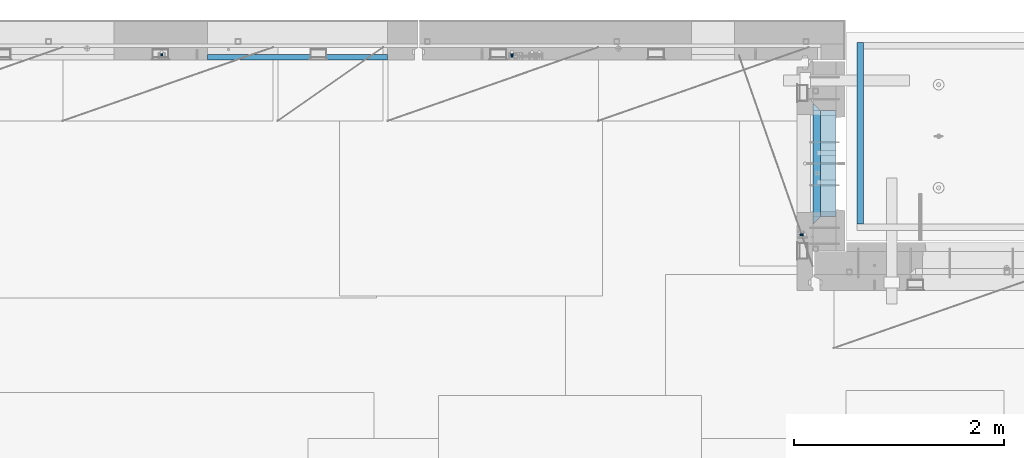
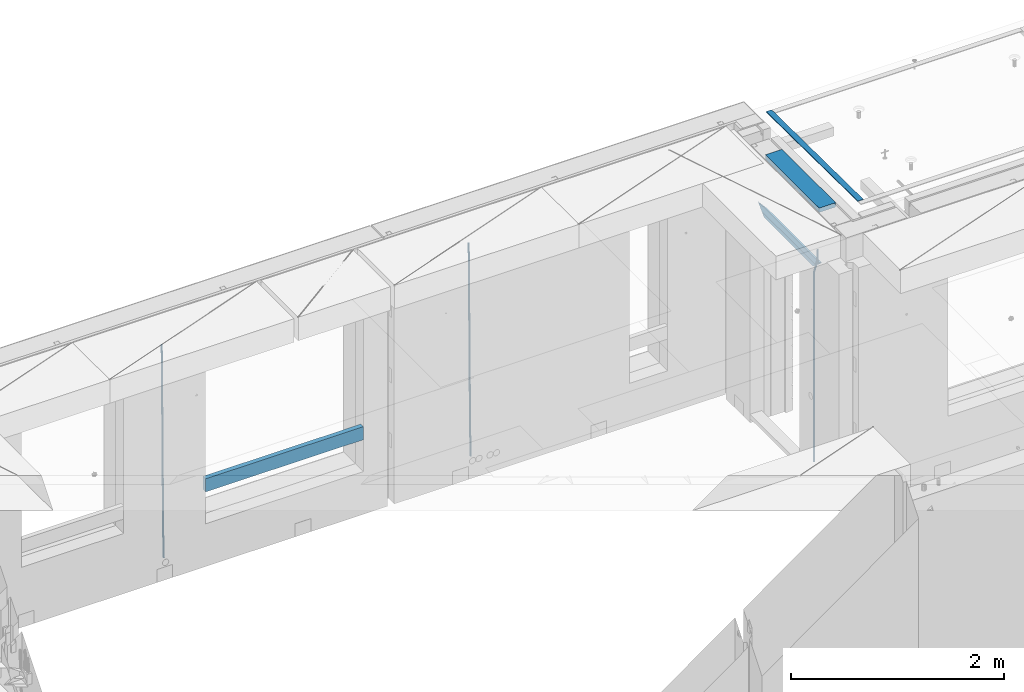
# One storey, part 127 of 349: 8 beams, 4 elements without a shape of their own.
"""IFC2X3 building model written with IfcOpenShell, lengths in millimetres."""

from ifc_helpers import new_model, si_unit, frame, origin_with_axes, place, context, subcontext, project, spatial, faceted_brep, material, type_object, element, aggregate, save


model = new_model("IFC2X3")

# Units and contexts
model_context = context("Model", 3, precision=1e-05, world=origin_with_axes())
body_context = subcontext(model_context, "Body", "Model", "MODEL_VIEW")
ifc_project = project(units=[si_unit("LENGTHUNIT", "METRE", prefix="MILLI"), si_unit("AREAUNIT", "SQUARE_METRE"), si_unit("VOLUMEUNIT", "CUBIC_METRE"), si_unit("MASSUNIT", "GRAM", prefix="KILO"), si_unit("TIMEUNIT", "SECOND"), si_unit("PLANEANGLEUNIT", "RADIAN"), si_unit("SOLIDANGLEUNIT", "STERADIAN"), si_unit("THERMODYNAMICTEMPERATUREUNIT", "DEGREE_CELSIUS"), si_unit("LUMINOUSINTENSITYUNIT", "LUMEN")], contexts=[model_context])

# Site, building, storey
site_placement = place(None, origin_with_axes())
site = spatial("IfcSite", under=ifc_project, at=site_placement, CompositionType="ELEMENT")
building_placement = place(site_placement, origin_with_axes())
building = spatial("IfcBuilding", under=site, at=building_placement, CompositionType="ELEMENT")
storey_placement = place(building_placement, origin_with_axes())
storey = spatial("IfcBuildingStorey", under=building, at=storey_placement, Name="4", CompositionType="ELEMENT", Elevation=0.0)

# Assembly, beams
assembly_1_placement = place(storey_placement, origin_with_axes())
assembly_1 = element("IfcElementAssembly", 1, at=assembly_1_placement, inside=storey, AssemblyPlace="NOTDEFINED", PredefinedType="REINFORCEMENT_UNIT")
ifc_material_1 = material(Name="CONCRETE/C25/30")
beam_type_1 = type_object("IfcBeamType", PredefinedType="NOTDEFINED")
beam_1_placement = place(assembly_1_placement, frame((31494.9951872276, 21060.0002716511, 93140.0), z_axis=(0.0, 0.0, -1.0), x_axis=(0.0, 1.0, 0.0)))
beam_1 = element("IfcBeam", 2, at=beam_1_placement, type_object=beam_type_1, material=ifc_material_1, Name="SK", context=body_context, shape_type="Brep", body=[
    faceted_brep([(70.0000000000164, -35.0, 35.0), (70.0000000000164, 35.0, 35.0), (0.0, -35.0, -35.0), (1079.99961853027, 35.0, 35.0), (1149.99961853027, -35.0, -35.0), (1079.99961853027, -35.0, 35.0)], [[[0, 1, 2]], [[2, 1, 3, 4]], [[0, 2, 4, 5]], [[1, 0, 5, 3]], [[4, 3, 5]]]),
])
beam_type_2 = type_object("IfcBeamType", PredefinedType="NOTDEFINED")
beam_2_placement = place(assembly_1_placement, frame((31494.9951872276, 21130.0002716511, 93080.0), z_axis=(0.0, 0.0, -1.0), x_axis=(0.0, 1.0, 0.0)))
beam_2 = element("IfcBeam", 3, at=beam_2_placement, type_object=beam_type_2, material=ifc_material_1, Name="SK", context=body_context, shape_type="Brep", body=[
    faceted_brep([(0.0, -35.0, -25.0), (43.8457723764295, -35.0, 18.8461538461561), (45.6406441713007, 35.0, 20.6410256410309), (0.0, 35.0, -25.0), (1009.99961853027, 35.0, -25.0), (1009.99961853027, -35.0, -25.0), (966.153464684117, -35.0, 18.8461538461561), (964.358592889246, 35.0, 20.6410256410309)], [[[0, 1, 2, 3]], [[0, 3, 4, 5]], [[1, 0, 5, 6]], [[6, 7, 2, 1]], [[3, 2, 7, 4]], [[6, 5, 4, 7]]]),
])
ifc_material_2 = material()
beam_type_3 = type_object("IfcBeamType", Name="D20", PredefinedType="NOTDEFINED")
beam_3_placement = place(assembly_1_placement, frame((31384.9951872298, 20959.9999999916, 93407.5), z_axis=(-0.999999913638316, 0.000415599999849952, 0.0), x_axis=(0.0, 0.0, -1.0)))
beam_3 = element("IfcBeam", 4, at=beam_3_placement, type_object=beam_type_3, material=ifc_material_2, Name="JM20", ObjectType="D20", context=body_context, shape_type="Brep", body=[
    faceted_brep([(0.0, -10.0, 0.0), (-4.19531716033816e-08, -7.07106781186667, -7.07106781187031), (113.248091332178, -7.0710684840451, -7.0710678117357), (113.248091314759, -10.0000006713562, -2.51020537689328e-10), (0.0, 0.0, -10.0), (113.248091374131, -6.72178430249915e-07, -9.99999999986903), (4.196772351861e-08, 7.07106781186303, -7.07106781186667), (113.248091416113, 7.07106713968824, -7.07106781173934), (0.0, 10.0, 0.0), (113.248091433488, 9.99999932782521, 1.30967237055302e-10), (4.196772351861e-08, 7.07106781185939, 7.07106781185939), (113.248091416113, 7.0710671396846, 7.071067811994), (0.0, 0.0, 10.0), (113.248091374131, -6.72174792271107e-07, 10.0000000001273), (-4.19531716033816e-08, -7.07106781187031, 7.07106781185939), (113.248091332178, -7.0710684840451, 7.071067811994), (130.699843527167, -7.06993249763036, -4.33745683788584), (128.538066582521, -9.99900540317321, 2.39499413731755), (131.594536475241, 0.00119355250353692, -7.12624594330919), (130.698046432328, 7.07220300913468, -4.33773834422391), (128.535525107087, 10.0009944322555, 2.39459602660281), (126.373748162892, 7.07192152754578, 9.1270470011732), (125.479055214906, 0.000795477419160306, 11.9158361066184), (126.37554525779, -7.07021397921199, 9.12732850753673), (240.336258550378, -7.05529970173666, 30.8729495437874), (238.174481606227, -9.98437260450009, 37.6054005176375), (241.230951498423, 0.0158263482953771, 28.0841604381058), (240.334461455612, 7.0868358050102, 30.8726680369582), (238.171940130502, 10.0156272283348, 37.6050024077231), (236.010163186409, 7.08655432384694, 44.3374533824244), (235.115470238379, 0.0154282738185429, 47.1262424881097), (236.011960281176, -7.05558118289991, 44.3377348892536), (253.461915329972, -7.05444528127919, 32.9289287376414), (253.46191532613, -9.98337746617108, 39.9999965521893), (253.461915339081, 0.0166225284556276, 29.9999965443676), (253.461915348205, 7.08769034247234, 32.9289287273205), (253.461915352003, 10.0166225357716, 39.9999965370152), (253.461915348293, 7.08769035281148, 47.0710643509774), (253.461915339183, 0.0166225430875784, 49.999996544273), (253.46191533003, -7.05444527093641, 47.0710643613093), (2417.50000002384, -7.0544364694706, 32.9289287374122), (2417.5000000337, -9.98336865393321, 39.9999965507959), (2417.49999999997, 0.0166313408753922, 29.9999965456082), (2417.49999997609, 7.08769915426274, 32.9289287300708), (2417.4999999662, 10.0166313460668, 39.9999965404204), (2417.49999997608, 7.08769916160054, 47.0710643538114), (2417.49999999994, 0.0166313512581837, 49.9999965456154), (2417.50000002382, -7.05443646212916, 47.0710643611455)], [[[0, 1, 2, 3]], [[1, 4, 5, 2]], [[4, 6, 7, 5]], [[6, 8, 9, 7]], [[8, 10, 11, 9]], [[10, 12, 13, 11]], [[12, 14, 15, 13]], [[14, 0, 3, 15]], [[14, 12, 10, 8, 6, 4, 1, 0]], [[3, 2, 16, 17]], [[2, 5, 18, 16]], [[5, 7, 19, 18]], [[7, 9, 20, 19]], [[9, 11, 21, 20]], [[11, 13, 22, 21]], [[13, 15, 23, 22]], [[15, 3, 17, 23]], [[17, 16, 24, 25]], [[16, 18, 26, 24]], [[18, 19, 27, 26]], [[19, 20, 28, 27]], [[20, 21, 29, 28]], [[21, 22, 30, 29]], [[22, 23, 31, 30]], [[23, 17, 25, 31]], [[25, 24, 32, 33]], [[24, 26, 34, 32]], [[26, 27, 35, 34]], [[27, 28, 36, 35]], [[28, 29, 37, 36]], [[29, 30, 38, 37]], [[30, 31, 39, 38]], [[31, 25, 33, 39]], [[33, 32, 40, 41]], [[32, 34, 42, 40]], [[34, 35, 43, 42]], [[35, 36, 44, 43]], [[36, 37, 45, 44]], [[37, 38, 46, 45]], [[38, 39, 47, 46]], [[39, 33, 41, 47]], [[42, 43, 44, 45, 46, 47, 41, 40]]]),
])

# Assembly, beam
assembly_2_placement = place(storey_placement, origin_with_axes())
assembly_2 = element("IfcElementAssembly", 5, at=assembly_2_placement, inside=storey, AssemblyPlace="NOTDEFINED", PredefinedType="REINFORCEMENT_UNIT")
beam_4_placement = place(assembly_2_placement, frame((28600.0000000039, 22654.9999977209, 90990.0), z_axis=(-0.000205762999925498, 0.999642804629538, -0.0267249099901004), x_axis=(4.30000201928125e-08, 0.0267249099948059, 0.999642825806181)))
beam_4 = element("IfcBeam", 6, at=beam_4_placement, type_object=beam_type_3, material=ifc_material_2, Name="JM20", ObjectType="D20", context=body_context, shape_type="Brep", body=[
    faceted_brep([(0.0, -10.0, 0.0), (-4.19531716033816e-08, -7.07106781186667, -7.07106781187031), (60.4266690400545, -7.0710677960451, -7.07106780570757), (60.4266690441291, -9.99999998418934, 6.15546014159918e-09), (0.0, 0.0, -10.0), (60.426669036824, 1.58106558956206e-08, -9.99999999384454), (4.196772351861e-08, 7.07106781186303, -7.07106781186667), (60.4266690363438, 7.07106782768096, -7.07106780570757), (0.0, 10.0, 0.0), (60.4266690388904, 10.0000000158179, 6.15182216279209e-09), (4.196772351861e-08, 7.07106781185939, 7.07106781185939), (60.4266690429649, 7.07106782768096, 7.07106781802577), (0.0, 0.0, 10.0), (60.4266690461809, 1.58179318532348e-08, 10.0000000061555), (-4.19531716033816e-08, -7.07106781187031, 7.07106781185939), (60.4266690466611, -7.07106779605238, 7.07106781802213), (61.0378400410118, -7.07106779588503, -7.07106780564936), (60.991799419251, -9.99999998403655, 6.21366780251265e-09), (61.0569027789461, 1.5985278878361e-08, -9.99999999378269), (61.0378209396877, 7.07106782784831, -7.07106780564936), (60.9917724058905, 10.0000000159635, 6.21366780251265e-09), (60.9457317841297, 7.07106782781193, 7.0710678180767), (60.9266690461809, 1.59488990902901e-08, 10.0000000062028), (60.9457508854539, -7.07106779591413, 7.0710678180767), (61.6489592143771, -7.07106614513759, -7.06310863441468), (61.5568818710308, -9.9999984576425, 0.00735959856683621), (61.6870830769039, 1.71821739058942e-06, -9.99179257185824), (61.6489210170112, 7.07106947854481, -7.06310888312146), (61.556827851804, 10.0000015422847, 0.00735924683976918), (61.4647505084577, 7.07106922979438, 7.07782747982128), (61.4266266459163, 1.36643211590126e-06, 10.0065114172685), (61.464788705809, -7.07106639389531, 7.07782772852806), (176.543135720174, -7.07075579406956, -5.56673531796696), (176.451058376813, -9.99968810657447, 1.50373291501455), (176.581259582701, 0.000312069292704109, -8.49541925541052), (176.543097522794, 7.07137982961285, -5.56673556667374), (176.451004357587, 10.00031189336, 1.50373256329476), (176.35892701424, 7.07137958085514, 8.57420079627263), (176.320803151699, 0.000311717507429421, 11.5028847337162), (176.358965211621, -7.07075604281999, 8.57420104497578), (177.098753836006, -7.07075429323595, -5.55949898843028), (176.98362511232, -9.99968666800123, 1.510669025065), (177.146421932586, 0.000313595905026887, -8.48805862247536), (177.098706077581, 7.07138133041735, -5.55949936166144), (176.983557571715, 10.0003133318824, 1.51066849724157), (176.868428848029, 7.07138095712435, 8.58083651073321), (176.820760751449, 0.000313067976094317, 11.5093961447819), (176.868476606425, -7.07075466652896, 8.58083688396073), (177.654312950661, -7.07075204110879, -5.54863964998367), (177.516135294456, -9.99968450931192, 1.52107783331303), (177.711524267797, 0.000315886711177882, -8.47701274570863), (177.654255632195, 7.07138358250813, -5.54864021007961), (177.516054233929, 10.0003154905207, 1.5210770412159), (177.377876577739, 7.0713830223176, 8.59079452451624), (177.320665260588, 0.000315094497636892, 11.5191676202448), (177.377933896176, -7.07075260129932, 8.59079508461218), (299.436796249574, -7.07025836271714, -3.1681962331204), (299.298618593355, -9.99919083092027, 3.90152125031091), (299.494007566798, 0.000809565110102994, -6.09656932889993), (299.436738931283, 7.07187726089978, -3.16819679320906), (299.298537533061, 10.0008091689197, 3.90152045822106), (299.160359876842, 7.07187670072017, 10.9712379416487), (299.103148559603, 0.000808772889286047, 13.8996110374392), (299.160417195119, -7.07025892290039, 10.9712385017483), (299.98743051647, -7.07025613056248, -3.15743315966392), (299.971788958996, -9.99918809853989, 3.91467979818117), (299.993912075952, 0.000811591617093654, -6.08679785393178), (299.987423933868, 7.07187949325817, -3.1574327280432), (299.971753863239, 10.0008119014747, 3.91467990454839), (299.95611230444, 7.07187992653053, 10.9867922621015), (299.949630744944, 0.000812204350950196, 13.9161569563694), (299.956118887014, -7.07025569729012, 10.9867918304735), (300.538107039494, -7.07025785017686, -3.16575821840888), (300.644985195438, -9.99919020432935, 3.90450175465594), (300.493854948218, 0.000810030429420294, -6.09435592770024), (300.538151196495, 7.071877773491, -3.16575855385963), (300.645047642858, 10.0008097955724, 3.90450128024895), (300.751925798773, 7.07187744142357, 10.9747612533101), (300.796177890064, 0.000809560813650023, 13.9033589625978), (300.751881641787, -7.07025818224065, 10.9747615887682), (2293.36490490142, -7.07648090940347, -33.2930642912361), (2293.47178305736, -10.0054132635523, -26.2228043181785), (2293.32065281013, -0.00541302880083094, -36.2216620005347), (2293.36494905842, 7.06565471425711, -33.2930646266868), (2293.47184550477, 9.99458673634581, -26.2228047925819), (2293.57872366071, 7.06565438219332, -19.1525448195243), (2293.62297575199, -0.00541349841296324, -16.2239471102366), (2293.57867950371, -7.0764812414709, -19.1525444840736), (2294.0658245362, -7.07648309818615, -33.3036607065333), (2294.05312277409, -10.0054150789219, -26.2315929392535), (2294.10928714235, -0.00541549149056664, -36.2335844756526), (2294.15805078732, 7.06565223761572, -33.3050546393533), (2294.18355038921, 9.99458451388637, -26.2335642579346), (2294.17084862708, 7.06565253314329, -19.1614964906439), (2294.12738602093, -0.00541507354500936, -16.2315727215355), (2294.07862237596, -7.07648280265857, -19.1601025578348), (2294.76670261032, -7.08562269121467, -33.294332712383), (2294.63442802057, -10.0129954178956, -26.2238563411993), (2294.89787471293, -0.0156988342423574, -36.2230891548279), (2294.95110548967, 7.05531064255774, -33.2944998654275), (2294.89521307347, 9.98530428734011, -26.2240927312887), (2294.76293848372, 7.0579315606592, -19.1536163601049), (2294.63176638114, -0.0119922963167483, -16.2248599176673), (2294.57853560438, -7.08300177311321, -19.1534492070678), (2316.52657204497, -7.36937582653991, -33.0047303660212), (2316.39429745522, -10.2967485532172, -25.9342539948302), (2316.65774414754, -0.299451969567599, -35.9334868084661), (2316.7109749243, 6.7715575072325, -33.0048975190657), (2316.65508250811, 9.70155115201487, -25.9344903849269), (2316.52280791836, 6.7741784253376, -18.8640140137468), (2316.39163581574, -0.295745431634714, -15.9352575713092), (2316.33840503903, -7.36675490843481, -18.863846860706), (2317.16202064224, -7.37766220584308, -32.9962731735213), (2317.05438744847, -10.3053562613532, -25.9254688497131), (2317.23607125619, -0.306993473008333, -35.925789846493), (2317.23316144495, 6.76474808850253, -32.9979477328052), (2317.15499573652, 9.6950321815566, -25.9278370341635), (2317.04736254275, 6.7673381260538, -18.8570327103698), (2316.97331192881, -0.303330606784584, -15.9275160373909), (2316.97622174003, -7.37507216829545, -18.8553581510787), (2317.79752306276, -7.37578610372293, -32.9880110666527), (2317.71453320107, -10.3033876998124, -25.9168792378296), (2317.81444760226, -0.305295583297266, -35.918287695793), (2317.75539265381, 6.76628640723357, -32.9911928173897), (2317.65495180529, 9.69652304524061, -25.9213789128698), (2317.5719619436, 6.76892144914746, -18.8502470840467), (2317.55503740412, -0.301569071270933, -15.9199704549137), (2317.61409235255, -7.3731510618054, -18.847065333317), (2417.8183084176, -7.07752398473531, -31.6906369377139), (2417.73531855589, -10.0051255808248, -24.6195051088798), (2417.83523295709, -0.007033464313281, -34.6209135668432), (2417.77617800863, 7.06454852621755, -31.6938186884508), (2417.67573716014, 9.99478516423187, -24.6240047839383), (2417.59274729842, 7.06718356813872, -17.5528729551006), (2417.57582275895, -0.00330695228694822, -14.6225963259749), (2417.6348777074, -7.07488894281778, -17.5496912043673)], [[[0, 1, 2, 3]], [[1, 4, 5, 2]], [[4, 6, 7, 5]], [[6, 8, 9, 7]], [[8, 10, 11, 9]], [[10, 12, 13, 11]], [[12, 14, 15, 13]], [[14, 0, 3, 15]], [[14, 12, 10, 8, 6, 4, 1, 0]], [[3, 2, 16, 17]], [[2, 5, 18, 16]], [[5, 7, 19, 18]], [[7, 9, 20, 19]], [[9, 11, 21, 20]], [[11, 13, 22, 21]], [[13, 15, 23, 22]], [[15, 3, 17, 23]], [[17, 16, 24, 25]], [[16, 18, 26, 24]], [[18, 19, 27, 26]], [[19, 20, 28, 27]], [[20, 21, 29, 28]], [[21, 22, 30, 29]], [[22, 23, 31, 30]], [[23, 17, 25, 31]], [[25, 24, 32, 33]], [[24, 26, 34, 32]], [[26, 27, 35, 34]], [[27, 28, 36, 35]], [[28, 29, 37, 36]], [[29, 30, 38, 37]], [[30, 31, 39, 38]], [[31, 25, 33, 39]], [[33, 32, 40, 41]], [[32, 34, 42, 40]], [[34, 35, 43, 42]], [[35, 36, 44, 43]], [[36, 37, 45, 44]], [[37, 38, 46, 45]], [[38, 39, 47, 46]], [[39, 33, 41, 47]], [[41, 40, 48, 49]], [[40, 42, 50, 48]], [[42, 43, 51, 50]], [[43, 44, 52, 51]], [[44, 45, 53, 52]], [[45, 46, 54, 53]], [[46, 47, 55, 54]], [[47, 41, 49, 55]], [[49, 48, 56, 57]], [[48, 50, 58, 56]], [[50, 51, 59, 58]], [[51, 52, 60, 59]], [[52, 53, 61, 60]], [[53, 54, 62, 61]], [[54, 55, 63, 62]], [[55, 49, 57, 63]], [[57, 56, 64, 65]], [[56, 58, 66, 64]], [[58, 59, 67, 66]], [[59, 60, 68, 67]], [[60, 61, 69, 68]], [[61, 62, 70, 69]], [[62, 63, 71, 70]], [[63, 57, 65, 71]], [[65, 64, 72, 73]], [[64, 66, 74, 72]], [[66, 67, 75, 74]], [[67, 68, 76, 75]], [[68, 69, 77, 76]], [[69, 70, 78, 77]], [[70, 71, 79, 78]], [[71, 65, 73, 79]], [[73, 72, 80, 81]], [[72, 74, 82, 80]], [[74, 75, 83, 82]], [[75, 76, 84, 83]], [[76, 77, 85, 84]], [[77, 78, 86, 85]], [[78, 79, 87, 86]], [[79, 73, 81, 87]], [[81, 80, 88, 89]], [[80, 82, 90, 88]], [[82, 83, 91, 90]], [[83, 84, 92, 91]], [[84, 85, 93, 92]], [[85, 86, 94, 93]], [[86, 87, 95, 94]], [[87, 81, 89, 95]], [[89, 88, 96, 97]], [[88, 90, 98, 96]], [[90, 91, 99, 98]], [[91, 92, 100, 99]], [[92, 93, 101, 100]], [[93, 94, 102, 101]], [[94, 95, 103, 102]], [[95, 89, 97, 103]], [[97, 96, 104, 105]], [[96, 98, 106, 104]], [[98, 99, 107, 106]], [[99, 100, 108, 107]], [[100, 101, 109, 108]], [[101, 102, 110, 109]], [[102, 103, 111, 110]], [[103, 97, 105, 111]], [[105, 104, 112, 113]], [[104, 106, 114, 112]], [[106, 107, 115, 114]], [[107, 108, 116, 115]], [[108, 109, 117, 116]], [[109, 110, 118, 117]], [[110, 111, 119, 118]], [[111, 105, 113, 119]], [[113, 112, 120, 121]], [[112, 114, 122, 120]], [[114, 115, 123, 122]], [[115, 116, 124, 123]], [[116, 117, 125, 124]], [[117, 118, 126, 125]], [[118, 119, 127, 126]], [[119, 113, 121, 127]], [[121, 120, 128, 129]], [[120, 122, 130, 128]], [[122, 123, 131, 130]], [[123, 124, 132, 131]], [[124, 125, 133, 132]], [[125, 126, 134, 133]], [[126, 127, 135, 134]], [[127, 121, 129, 135]], [[130, 131, 132, 133, 134, 135, 129, 128]]]),
])
aggregate(assembly_2, [beam_4])

# Assembly, beams
assembly_3_placement = place(storey_placement, origin_with_axes())
assembly_3 = element("IfcElementAssembly", 7, at=assembly_3_placement, inside=storey, AssemblyPlace="NOTDEFINED", PredefinedType="REINFORCEMENT_UNIT")
beam_5_placement = place(assembly_3_placement, frame((25270.0000000039, 22654.999995444, 90990.0), z_axis=(-0.000205762999925498, 0.999642804629538, -0.0267249099901004), x_axis=(4.30000201928125e-08, 0.0267249099948059, 0.999642825806181)))
beam_5 = element("IfcBeam", 8, at=beam_5_placement, type_object=beam_type_3, material=ifc_material_2, Name="JM20", ObjectType="D20", context=body_context, shape_type="Brep", body=[
    faceted_brep([(0.0, -10.0, 0.0), (-4.19531716033816e-08, -7.07106781186667, -7.07106781187031), (60.4266690400545, -7.0710677960451, -7.07106780570757), (60.4266690441291, -9.99999998418934, 6.15546014159918e-09), (0.0, 0.0, -10.0), (60.426669036824, 1.58106558956206e-08, -9.99999999384454), (4.196772351861e-08, 7.07106781186303, -7.07106781186667), (60.4266690363438, 7.07106782768096, -7.07106780570757), (0.0, 10.0, 0.0), (60.4266690388904, 10.0000000158179, 6.15182216279209e-09), (4.196772351861e-08, 7.07106781185939, 7.07106781185939), (60.4266690429649, 7.07106782768096, 7.07106781802577), (0.0, 0.0, 10.0), (60.4266690461809, 1.58179318532348e-08, 10.0000000061555), (-4.19531716033816e-08, -7.07106781187031, 7.07106781185939), (60.4266690466611, -7.07106779605238, 7.07106781802213), (61.0378400410118, -7.07106779588503, -7.07106780564936), (60.991799419251, -9.99999998403655, 6.21366780251265e-09), (61.0569027789461, 1.5985278878361e-08, -9.99999999378269), (61.0378209396877, 7.07106782784831, -7.07106780564936), (60.9917724058905, 10.0000000159635, 6.21366780251265e-09), (60.9457317841297, 7.07106782781193, 7.0710678180767), (60.9266690461809, 1.59488990902901e-08, 10.0000000062028), (60.9457508854539, -7.07106779591413, 7.0710678180767), (61.6489592143771, -7.07106614513759, -7.06310863441468), (61.5568818710308, -9.9999984576425, 0.00735959856683621), (61.6870830769039, 1.71821739058942e-06, -9.99179257185824), (61.6489210170112, 7.07106947854481, -7.06310888312146), (61.556827851804, 10.0000015422847, 0.00735924683976918), (61.4647505084577, 7.07106922979438, 7.07782747982128), (61.4266266459163, 1.36643211590126e-06, 10.0065114172685), (61.464788705809, -7.07106639389531, 7.07782772852806), (176.543135720174, -7.07075579406956, -5.56673531796696), (176.451058376813, -9.99968810657447, 1.50373291501455), (176.581259582701, 0.000312069292704109, -8.49541925541052), (176.543097522794, 7.07137982961285, -5.56673556667374), (176.451004357587, 10.00031189336, 1.50373256329476), (176.35892701424, 7.07137958085514, 8.57420079627263), (176.320803151699, 0.000311717507429421, 11.5028847337162), (176.358965211621, -7.07075604281999, 8.57420104497578), (177.098753836006, -7.07075429323595, -5.55949898843028), (176.98362511232, -9.99968666800123, 1.510669025065), (177.146421932586, 0.000313595905026887, -8.48805862247536), (177.098706077581, 7.07138133041735, -5.55949936166144), (176.983557571715, 10.0003133318824, 1.51066849724157), (176.868428848029, 7.07138095712435, 8.58083651073321), (176.820760751449, 0.000313067976094317, 11.5093961447819), (176.868476606425, -7.07075466652896, 8.58083688396073), (177.654312950661, -7.07075204110879, -5.54863964998367), (177.516135294456, -9.99968450931192, 1.52107783331303), (177.711524267797, 0.000315886711177882, -8.47701274570863), (177.654255632195, 7.07138358250813, -5.54864021007961), (177.516054233929, 10.0003154905207, 1.5210770412159), (177.377876577739, 7.0713830223176, 8.59079452451624), (177.320665260588, 0.000315094497636892, 11.5191676202448), (177.377933896176, -7.07075260129932, 8.59079508461218), (299.436796249574, -7.07025836271714, -3.1681962331204), (299.298618593355, -9.99919083092027, 3.90152125031091), (299.494007566798, 0.000809565110102994, -6.09656932889993), (299.436738931283, 7.07187726089978, -3.16819679320906), (299.298537533061, 10.0008091689197, 3.90152045822106), (299.160359876842, 7.07187670072017, 10.9712379416487), (299.103148559603, 0.000808772889286047, 13.8996110374392), (299.160417195119, -7.07025892290039, 10.9712385017483), (299.98743051647, -7.07025613056248, -3.15743315966392), (299.971788958996, -9.99918809853989, 3.91467979818117), (299.993912075952, 0.000811591617093654, -6.08679785393178), (299.987423933868, 7.07187949325817, -3.1574327280432), (299.971753863239, 10.0008119014747, 3.91467990454839), (299.95611230444, 7.07187992653053, 10.9867922621015), (299.949630744944, 0.000812204350950196, 13.9161569563694), (299.956118887014, -7.07025569729012, 10.9867918304735), (300.538107039494, -7.07025785017686, -3.16575821840888), (300.644985195438, -9.99919020432935, 3.90450175465594), (300.493854948218, 0.000810030429420294, -6.09435592770024), (300.538151196495, 7.071877773491, -3.16575855385963), (300.645047642858, 10.0008097955724, 3.90450128024895), (300.751925798773, 7.07187744142357, 10.9747612533101), (300.796177890064, 0.000809560813650023, 13.9033589625978), (300.751881641787, -7.07025818224065, 10.9747615887682), (2293.36490490142, -7.07648090940347, -33.2930642912361), (2293.47178305736, -10.0054132635523, -26.2228043181785), (2293.32065281013, -0.00541302880083094, -36.2216620005347), (2293.36494905842, 7.06565471425711, -33.2930646266868), (2293.47184550477, 9.99458673634581, -26.2228047925819), (2293.57872366071, 7.06565438219332, -19.1525448195243), (2293.62297575199, -0.00541349841296324, -16.2239471102366), (2293.57867950371, -7.0764812414709, -19.1525444840736), (2294.0658245362, -7.07648309818615, -33.3036607065333), (2294.05312277409, -10.0054150789219, -26.2315929392535), (2294.10928714235, -0.00541549149056664, -36.2335844756526), (2294.15805078732, 7.06565223761572, -33.3050546393533), (2294.18355038921, 9.99458451388637, -26.2335642579346), (2294.17084862708, 7.06565253314329, -19.1614964906439), (2294.12738602093, -0.00541507354500936, -16.2315727215355), (2294.07862237596, -7.07648280265857, -19.1601025578348), (2294.76670261032, -7.08562269121467, -33.294332712383), (2294.63442802057, -10.0129954178956, -26.2238563411993), (2294.89787471293, -0.0156988342423574, -36.2230891548279), (2294.95110548967, 7.05531064255774, -33.2944998654275), (2294.89521307347, 9.98530428734011, -26.2240927312887), (2294.76293848372, 7.0579315606592, -19.1536163601049), (2294.63176638114, -0.0119922963167483, -16.2248599176673), (2294.57853560438, -7.08300177311321, -19.1534492070678), (2316.52657204497, -7.36937582653991, -33.0047303660212), (2316.39429745522, -10.2967485532172, -25.9342539948302), (2316.65774414754, -0.299451969567599, -35.9334868084661), (2316.7109749243, 6.7715575072325, -33.0048975190657), (2316.65508250811, 9.70155115201487, -25.9344903849269), (2316.52280791836, 6.7741784253376, -18.8640140137468), (2316.39163581574, -0.295745431634714, -15.9352575713092), (2316.33840503903, -7.36675490843481, -18.863846860706), (2317.16202064224, -7.37766220584308, -32.9962731735213), (2317.05438744847, -10.3053562613532, -25.9254688497131), (2317.23607125619, -0.306993473008333, -35.925789846493), (2317.23316144495, 6.76474808850253, -32.9979477328052), (2317.15499573652, 9.6950321815566, -25.9278370341635), (2317.04736254275, 6.7673381260538, -18.8570327103698), (2316.97331192881, -0.303330606784584, -15.9275160373909), (2316.97622174003, -7.37507216829545, -18.8553581510787), (2317.79752306276, -7.37578610372293, -32.9880110666527), (2317.71453320107, -10.3033876998124, -25.9168792378296), (2317.81444760226, -0.305295583297266, -35.918287695793), (2317.75539265381, 6.76628640723357, -32.9911928173897), (2317.65495180529, 9.69652304524061, -25.9213789128698), (2317.5719619436, 6.76892144914746, -18.8502470840467), (2317.55503740412, -0.301569071270933, -15.9199704549137), (2317.61409235255, -7.3731510618054, -18.847065333317), (2417.8183084176, -7.07752398473531, -31.6906369377139), (2417.73531855589, -10.0051255808248, -24.6195051088798), (2417.83523295709, -0.007033464313281, -34.6209135668432), (2417.77617800863, 7.06454852621755, -31.6938186884508), (2417.67573716014, 9.99478516423187, -24.6240047839383), (2417.59274729842, 7.06718356813872, -17.5528729551006), (2417.57582275895, -0.00330695228694822, -14.6225963259749), (2417.6348777074, -7.07488894281778, -17.5496912043673)], [[[0, 1, 2, 3]], [[1, 4, 5, 2]], [[4, 6, 7, 5]], [[6, 8, 9, 7]], [[8, 10, 11, 9]], [[10, 12, 13, 11]], [[12, 14, 15, 13]], [[14, 0, 3, 15]], [[14, 12, 10, 8, 6, 4, 1, 0]], [[3, 2, 16, 17]], [[2, 5, 18, 16]], [[5, 7, 19, 18]], [[7, 9, 20, 19]], [[9, 11, 21, 20]], [[11, 13, 22, 21]], [[13, 15, 23, 22]], [[15, 3, 17, 23]], [[17, 16, 24, 25]], [[16, 18, 26, 24]], [[18, 19, 27, 26]], [[19, 20, 28, 27]], [[20, 21, 29, 28]], [[21, 22, 30, 29]], [[22, 23, 31, 30]], [[23, 17, 25, 31]], [[25, 24, 32, 33]], [[24, 26, 34, 32]], [[26, 27, 35, 34]], [[27, 28, 36, 35]], [[28, 29, 37, 36]], [[29, 30, 38, 37]], [[30, 31, 39, 38]], [[31, 25, 33, 39]], [[33, 32, 40, 41]], [[32, 34, 42, 40]], [[34, 35, 43, 42]], [[35, 36, 44, 43]], [[36, 37, 45, 44]], [[37, 38, 46, 45]], [[38, 39, 47, 46]], [[39, 33, 41, 47]], [[41, 40, 48, 49]], [[40, 42, 50, 48]], [[42, 43, 51, 50]], [[43, 44, 52, 51]], [[44, 45, 53, 52]], [[45, 46, 54, 53]], [[46, 47, 55, 54]], [[47, 41, 49, 55]], [[49, 48, 56, 57]], [[48, 50, 58, 56]], [[50, 51, 59, 58]], [[51, 52, 60, 59]], [[52, 53, 61, 60]], [[53, 54, 62, 61]], [[54, 55, 63, 62]], [[55, 49, 57, 63]], [[57, 56, 64, 65]], [[56, 58, 66, 64]], [[58, 59, 67, 66]], [[59, 60, 68, 67]], [[60, 61, 69, 68]], [[61, 62, 70, 69]], [[62, 63, 71, 70]], [[63, 57, 65, 71]], [[65, 64, 72, 73]], [[64, 66, 74, 72]], [[66, 67, 75, 74]], [[67, 68, 76, 75]], [[68, 69, 77, 76]], [[69, 70, 78, 77]], [[70, 71, 79, 78]], [[71, 65, 73, 79]], [[73, 72, 80, 81]], [[72, 74, 82, 80]], [[74, 75, 83, 82]], [[75, 76, 84, 83]], [[76, 77, 85, 84]], [[77, 78, 86, 85]], [[78, 79, 87, 86]], [[79, 73, 81, 87]], [[81, 80, 88, 89]], [[80, 82, 90, 88]], [[82, 83, 91, 90]], [[83, 84, 92, 91]], [[84, 85, 93, 92]], [[85, 86, 94, 93]], [[86, 87, 95, 94]], [[87, 81, 89, 95]], [[89, 88, 96, 97]], [[88, 90, 98, 96]], [[90, 91, 99, 98]], [[91, 92, 100, 99]], [[92, 93, 101, 100]], [[93, 94, 102, 101]], [[94, 95, 103, 102]], [[95, 89, 97, 103]], [[97, 96, 104, 105]], [[96, 98, 106, 104]], [[98, 99, 107, 106]], [[99, 100, 108, 107]], [[100, 101, 109, 108]], [[101, 102, 110, 109]], [[102, 103, 111, 110]], [[103, 97, 105, 111]], [[105, 104, 112, 113]], [[104, 106, 114, 112]], [[106, 107, 115, 114]], [[107, 108, 116, 115]], [[108, 109, 117, 116]], [[109, 110, 118, 117]], [[110, 111, 119, 118]], [[111, 105, 113, 119]], [[113, 112, 120, 121]], [[112, 114, 122, 120]], [[114, 115, 123, 122]], [[115, 116, 124, 123]], [[116, 117, 125, 124]], [[117, 118, 126, 125]], [[118, 119, 127, 126]], [[119, 113, 121, 127]], [[121, 120, 128, 129]], [[120, 122, 130, 128]], [[122, 123, 131, 130]], [[123, 124, 132, 131]], [[124, 125, 133, 132]], [[125, 126, 134, 133]], [[126, 127, 135, 134]], [[127, 121, 129, 135]], [[130, 131, 132, 133, 134, 135, 129, 128]]]),
])
ifc_material_3 = material(Name="TIMBER/T24")
beam_type_4 = type_object("IfcBeamType", PredefinedType="NOTDEFINED")
beam_6_placement = place(assembly_3_placement, frame((27415.0002980493, 22644.9998418812, 91685.0), z_axis=(0.0, 0.0, 1.0), x_axis=(-1.0, 3.00000001838171e-08, 0.0)))
beam_6 = element("IfcBeam", 9, at=beam_6_placement, type_object=beam_type_4, material=ifc_material_3, context=body_context, shape_type="Brep", body=[
    faceted_brep([(-3.63797880709171e-12, 24.9999999999964, -75.0), (-3.63797880709171e-12, 24.9999999999964, 75.0), (1710.0, 25.0, 75.0), (1710.0, 25.0, -75.0), (0.0, -25.0000000000073, 75.0), (1709.99999999999, -25.0, 75.0), (0.0, -25.0000000000073, -75.0), (1709.99999999999, -25.0, -75.0)], [[[0, 1, 2, 3]], [[1, 4, 5, 2]], [[4, 6, 7, 5]], [[6, 0, 3, 7]], [[5, 7, 3, 2]], [[6, 4, 1, 0]]]),
])
aggregate(assembly_3, [beam_5, beam_6])

# Assembly, beam
assembly_4_placement = place(storey_placement, origin_with_axes())
assembly_4 = element("IfcElementAssembly", 10, at=assembly_4_placement, inside=storey, AssemblyPlace="NOTDEFINED", PredefinedType="REINFORCEMENT_UNIT")
ifc_material_4 = material(Name="CONCRETE/Concrete_Undefined")
beam_type_5 = type_object("IfcBeamType", PredefinedType="NOTDEFINED")
beam_7_placement = place(assembly_4_placement, frame((31909.9986098709, 21060.0524822207, 93725.2791116282), z_axis=(7.99999906921644e-09, 0.0107912409985276, 0.999941772863656), x_axis=(7.22999999800065e-07, 0.999941772863395, -0.0107912409985247)))
beam_7 = element("IfcBeam", 11, at=beam_7_placement, type_object=beam_type_5, material=ifc_material_4, context=body_context, shape_type="Brep", body=[
    faceted_brep([(2.5465851649642e-11, 29.9999999999982, -4.99999999998545), (-2.91038304567337e-11, 29.9999999999982, 5.0), (1725.04446838825, 29.9999999999927, 4.99999999998545), (1725.04446838825, 29.9999999999927, -5.00000000001455), (-2.5465851649642e-11, -30.0000000000018, 5.0), (1725.04446838824, -30.0000000000073, 4.99999999998545), (2.72848410531878e-11, -30.0000000000018, -4.99999999998545), (1725.04446838824, -30.0000000000073, -5.0)], [[[0, 1, 2, 3]], [[1, 4, 5, 2]], [[4, 6, 7, 5]], [[6, 0, 3, 7]], [[5, 7, 3, 2]], [[6, 4, 1, 0]]]),
])
aggregate(assembly_4, [beam_7])

# Beam
ifc_material_5 = material(Name="TIMBER")
beam_type_6 = type_object("IfcBeamType", PredefinedType="NOTDEFINED")
beam_8_placement = place(assembly_1_placement, frame((31589.9951872276, 22140.0000381475, 93715.0), z_axis=(0.0, 0.0, 1.0), x_axis=(0.0, -1.0, 0.0)))
beam_8 = element("IfcBeam", 12, at=beam_8_placement, type_object=beam_type_6, material=ifc_material_5, context=body_context, shape_type="Brep", body=[
    faceted_brep([(0.0, 90.0, -25.0), (0.0, 90.0, 25.0), (1009.99983857082, 90.0, 25.0), (1009.99983857082, 90.0, -25.0), (0.0, -90.0, 25.0), (1009.99983857082, -90.0, 25.0), (0.0, -90.0, -25.0), (1009.99983857082, -90.0, -25.0)], [[[0, 1, 2, 3]], [[1, 4, 5, 2]], [[4, 6, 7, 5]], [[6, 0, 3, 7]], [[5, 7, 3, 2]], [[6, 4, 1, 0]]]),
])

aggregate(assembly_1, [beam_3, beam_8, beam_1, beam_2])

save(model, "model.ifc")
